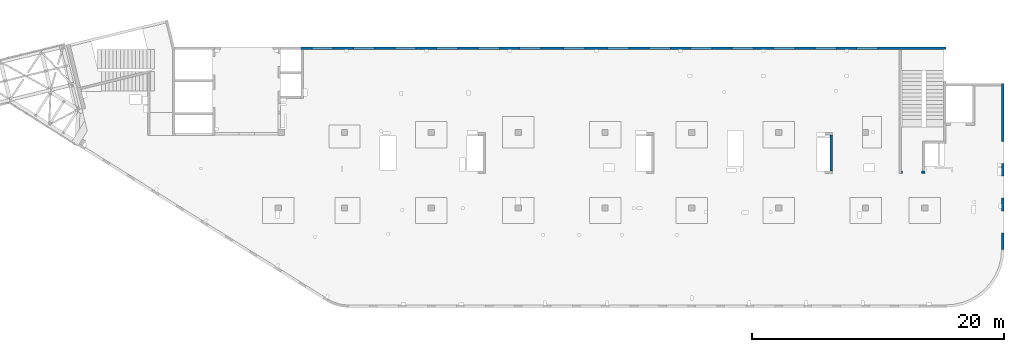
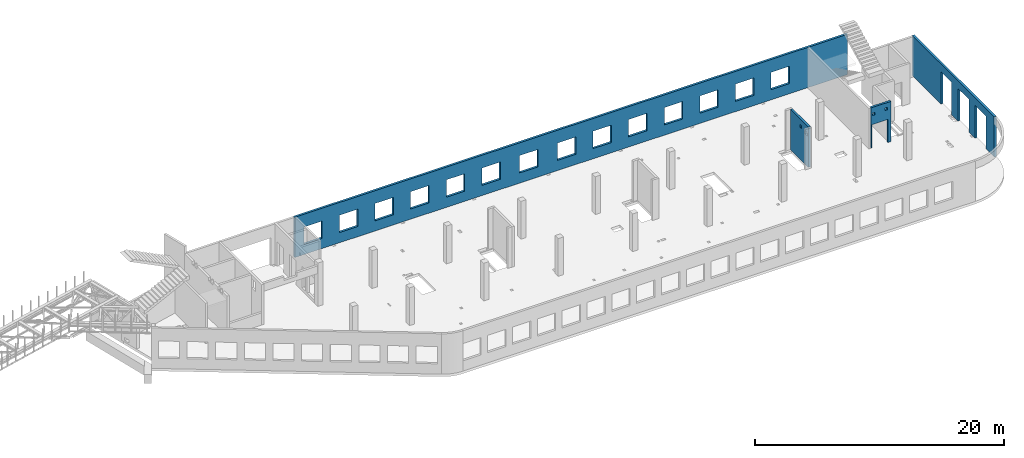
# One storey, part 66 of 66: 4 walls, 22 openings.
"""IFC4 building model written with IfcOpenShell, lengths in millimetres."""

from ifc_helpers import new_model, entity, si_unit, converted_unit, derived_unit, direction, frame, origin, place, context, subcontext, project, spatial, indexed_curve, outline, extrude, polygons, material, type_object, element, save


model = new_model("IFC4")

# Units and contexts
model_context = context("Model", 3, precision=0.01, world=origin(), true_north=direction((6.12303176911189e-17, 1.0)))
plan_context = context("Plan", 3, precision=0.01, world=origin(), true_north=direction((6.12303176911189e-17, 1.0)))
body_context = subcontext(model_context, "Body", "Model", "MODEL_VIEW")
ifc_project = project(units=[si_unit("LENGTHUNIT", "METRE", prefix="MILLI"), si_unit("AREAUNIT", "SQUARE_METRE"), si_unit("VOLUMEUNIT", "CUBIC_METRE"), converted_unit("PLANEANGLEUNIT", "DEGREE", entity("IfcRatioMeasure", 0.0174532925199433), si_unit("PLANEANGLEUNIT", "RADIAN"), dimensions=[0, 0, 0, 0, 0, 0, 0]), si_unit("MASSUNIT", "GRAM", prefix="KILO"), derived_unit("MASSDENSITYUNIT", [(si_unit("MASSUNIT", "GRAM", prefix="KILO"), 1), (si_unit("LENGTHUNIT", "METRE"), -3)]), derived_unit("MOMENTOFINERTIAUNIT", [(si_unit("LENGTHUNIT", "METRE"), 4)]), si_unit("TIMEUNIT", "SECOND"), si_unit("FREQUENCYUNIT", "HERTZ"), si_unit("THERMODYNAMICTEMPERATUREUNIT", "DEGREE_CELSIUS"), derived_unit("THERMALTRANSMITTANCEUNIT", [(si_unit("MASSUNIT", "GRAM", prefix="KILO"), 1), (si_unit("THERMODYNAMICTEMPERATUREUNIT", "KELVIN"), -1), (si_unit("TIMEUNIT", "SECOND"), -3)]), derived_unit("VOLUMETRICFLOWRATEUNIT", [(si_unit("LENGTHUNIT", "METRE"), 3), (si_unit("TIMEUNIT", "SECOND"), -1)]), derived_unit("MASSFLOWRATEUNIT", [(si_unit("MASSUNIT", "GRAM", prefix="KILO"), 1), (si_unit("TIMEUNIT", "SECOND"), -1)]), derived_unit("ROTATIONALFREQUENCYUNIT", [(si_unit("TIMEUNIT", "SECOND"), -1)]), si_unit("ELECTRICCURRENTUNIT", "AMPERE"), si_unit("ELECTRICVOLTAGEUNIT", "VOLT"), si_unit("POWERUNIT", "WATT"), si_unit("FORCEUNIT", "NEWTON", prefix="KILO"), si_unit("ILLUMINANCEUNIT", "LUX"), si_unit("LUMINOUSFLUXUNIT", "LUMEN"), si_unit("LUMINOUSINTENSITYUNIT", "CANDELA"), derived_unit("USERDEFINED", [(si_unit("MASSUNIT", "GRAM", prefix="KILO"), -1), (si_unit("LENGTHUNIT", "METRE"), -2), (si_unit("TIMEUNIT", "SECOND"), 3), (si_unit("LUMINOUSFLUXUNIT", "LUMEN"), 1)]), derived_unit("LINEARVELOCITYUNIT", [(si_unit("LENGTHUNIT", "METRE"), 1), (si_unit("TIMEUNIT", "SECOND"), -1)]), si_unit("PRESSUREUNIT", "PASCAL"), derived_unit("USERDEFINED", [(si_unit("LENGTHUNIT", "METRE"), -2), (si_unit("MASSUNIT", "GRAM", prefix="KILO"), 1), (si_unit("TIMEUNIT", "SECOND"), -2)]), derived_unit("LINEARFORCEUNIT", [(si_unit("MASSUNIT", "GRAM", prefix="KILO"), 1), (si_unit("LENGTHUNIT", "METRE"), 1), (si_unit("TIMEUNIT", "SECOND"), -2), (si_unit("LENGTHUNIT", "METRE"), -1)]), derived_unit("PLANARFORCEUNIT", [(si_unit("MASSUNIT", "GRAM", prefix="KILO"), 1), (si_unit("LENGTHUNIT", "METRE"), 1), (si_unit("TIMEUNIT", "SECOND"), -2), (si_unit("LENGTHUNIT", "METRE"), -2)])], contexts=[model_context, plan_context])

# Site, building, storey
site_placement = place(None, origin())
site = spatial("IfcSite", under=ifc_project, at=site_placement, CompositionType="ELEMENT")
building_placement = place(site_placement, origin())
building = spatial("IfcBuilding", under=site, at=building_placement, CompositionType="ELEMENT")
storey_placement = place(building_placement, frame((0.0, 0.0, 19800.0)))
storey = spatial("IfcBuildingStorey", under=building, at=storey_placement, Name="06", CompositionType="ELEMENT", Elevation=19800.0)

# Wall, openings
ifc_material = material()
wall_type = type_object("IfcWallType", Name=":ADSK_ 25_200", PredefinedType="STANDARD")
wall_1_placement = place(storey_placement, frame((68970.0, 20400.0, -150.0), z_axis=(0.0, 0.0, 1.0), x_axis=(-1.0, 0.0, 0.0)))
wall_1 = element("IfcWall", 1, at=wall_1_placement, inside=storey, type_object=wall_type, material=ifc_material, Name=":ADSK_ 25_200", ObjectType=":ADSK_ 25_200", PredefinedType="NOTDEFINED", context=body_context, shape_type="Tessellation", body=[
    polygons([(48700.0, -100.000000000319, 2700.0), (50400.0, -100.000000000319, 2700.0), (50400.0, -100.000000000319, 1000.00000000001), (48700.0, -100.000000000319, 1000.00000000001), (45400.0, -100.000000000319, 2700.0), (47100.0, -100.000000000319, 2700.0), (47100.0, -100.000000000319, 1000.00000000001), (45400.0, -100.000000000319, 1000.00000000001), (42100.0, -100.000000000315, 2700.0), (43800.0, -100.000000000319, 2700.0), (43800.0, -100.000000000319, 1000.00000000001), (42100.0, -100.000000000315, 1000.00000000001), (38800.0, -100.000000000315, 2700.0), (40500.0, -100.000000000315, 2700.0), (40500.0, -100.000000000315, 1000.00000000001), (38800.0, -100.000000000315, 1000.00000000001), (35500.0, -100.000000000315, 2700.0), (37200.0, -100.000000000315, 2700.0), (37200.0, -100.000000000315, 1000.00000000001), (35500.0, -100.000000000315, 1000.00000000001), (28700.0, -100.000000000315, 2700.0), (30400.0, -100.000000000315, 2700.0), (30400.0, -100.000000000315, 1000.00000000001), (28700.0, -100.000000000315, 1000.00000000001), (25200.0, -100.000000000319, 2700.0), (26900.0, -100.000000000315, 2700.0), (26900.0, -100.000000000315, 1000.00000000001), (25200.0, -100.000000000319, 1000.00000000001), (21900.0, -100.000000000319, 2700.0), (23600.0, -100.000000000319, 2700.0), (23600.0, -100.000000000319, 1000.00000000001), (21900.0, -100.000000000319, 1000.00000000001), (18600.0, -100.000000000319, 2700.0), (20300.0, -100.000000000319, 2700.0), (20300.0, -100.000000000319, 1000.00000000001), (18600.0, -100.000000000319, 1000.00000000001), (15300.0, -100.000000000319, 2700.0), (17000.0, -100.000000000319, 2700.0), (17000.0, -100.000000000319, 1000.00000000001), (15300.0, -100.000000000319, 1000.00000000001), (12000.0, -100.000000000319, 2700.0), (13700.0, -100.000000000319, 2700.0), (13700.0, -100.000000000319, 1000.00000000001), (12000.0, -100.000000000319, 1000.00000000001), (8700.00000000004, -100.000000000319, 2700.0), (10400.0, -100.000000000319, 2700.0), (10400.0, -100.000000000319, 1000.00000000001), (8700.00000000004, -100.000000000319, 1000.00000000001), (5400.00000000004, -100.000000000319, 2700.0), (7100.00000000004, -100.000000000319, 2700.0), (7100.00000000004, -100.000000000319, 1000.00000000001), (5400.00000000004, -100.000000000319, 1000.00000000001), (32200.0, -100.000000000315, 2700.0), (33900.0, -100.000000000315, 2700.0), (33900.0, -100.000000000315, 1000.00000000001), (32200.0, -100.000000000315, 1000.00000000001), (-1.0404017477463e-11, -99.9999999999989, 0.0), (3539.99999999995, -99.9999999999989, 0.0), (51245.0, -99.9999999999989, 0.0), (51245.0, -99.9999999999989, 3950.0), (3539.99999999995, -99.9999999999989, 3950.0), (-1.0404017477463e-11, -99.9999999999989, 3950.0), (-1.03870313266876e-11, 99.9999999999989, 0.0), (-1.03870313266876e-11, 99.9999999999989, 3950.0), (3539.99999999996, 99.9999999999989, 3950.0), (3739.99999999996, 99.9999999999989, 3950.0), (51045.0, 99.9999999999989, 3950.0), (51245.0, 99.9999999999989, 3950.0), (51245.0, 99.9999999999989, 0.0), (51045.0, 99.9999999999989, 0.0), (3739.99999999996, 99.9999999999989, 0.0), (3539.99999999996, 99.9999999999989, 0.0), (50400.0, 99.9999999999989, 2700.0), (48700.0, 99.9999999999989, 2700.0), (48700.0, 99.9999999999989, 1000.00000000001), (50400.0, 99.9999999999989, 1000.00000000001), (47100.0, 99.9999999999989, 2700.0), (45400.0, 99.9999999999989, 2700.0), (45400.0, 99.9999999999989, 1000.00000000001), (47100.0, 99.9999999999989, 1000.00000000001), (43800.0, 99.9999999999989, 2700.0), (42100.0, 100.000000000003, 2700.0), (42100.0, 100.000000000003, 1000.00000000001), (43800.0, 99.9999999999989, 1000.00000000001), (40500.0, 100.000000000003, 2700.0), (38800.0, 100.000000000003, 2700.0), (38800.0, 100.000000000003, 1000.00000000001), (40500.0, 100.000000000003, 1000.00000000001), (37200.0, 100.000000000003, 2700.0), (35500.0, 100.000000000003, 2700.0), (35500.0, 100.000000000003, 1000.00000000001), (37200.0, 100.000000000003, 1000.00000000001), (30400.0, 100.000000000003, 2700.0), (28700.0, 100.000000000003, 2700.0), (28700.0, 100.000000000003, 1000.00000000001), (30400.0, 100.000000000003, 1000.00000000001), (26900.0, 100.000000000003, 2700.0), (25200.0, 99.9999999999989, 2700.0), (25200.0, 99.9999999999989, 1000.00000000001), (26900.0, 100.000000000003, 1000.00000000001), (23600.0, 99.9999999999989, 2700.0), (21900.0, 99.9999999999989, 2700.0), (21900.0, 99.9999999999989, 1000.00000000001), (23600.0, 99.9999999999989, 1000.00000000001), (20300.0, 99.9999999999989, 2700.0), (18600.0, 99.9999999999989, 2700.0), (18600.0, 99.9999999999989, 1000.00000000001), (20300.0, 99.9999999999989, 1000.00000000001), (17000.0, 99.9999999999989, 2700.0), (15300.0, 99.9999999999989, 2700.0), (15300.0, 99.9999999999989, 1000.00000000001), (17000.0, 99.9999999999989, 1000.00000000001), (13700.0, 99.9999999999989, 2700.0), (12000.0, 99.9999999999989, 2700.0), (12000.0, 99.9999999999989, 1000.00000000001), (13700.0, 99.9999999999989, 1000.00000000001), (10400.0, 99.9999999999989, 2700.0), (8700.00000000004, 99.9999999999989, 2700.0), (8700.00000000004, 99.9999999999989, 1000.00000000001), (10400.0, 99.9999999999989, 1000.00000000001), (7100.00000000004, 99.9999999999989, 2700.0), (5400.00000000004, 99.9999999999989, 2700.0), (5400.00000000004, 99.9999999999989, 1000.00000000001), (7100.00000000004, 99.9999999999989, 1000.00000000001), (33900.0, 100.000000000003, 2700.0), (32200.0, 100.000000000003, 2700.0), (32200.0, 100.000000000003, 1000.00000000001), (33900.0, 100.000000000003, 1000.00000000001)], [[[57, 58, 59, 60, 61, 62], [1, 2, 3, 4], [5, 6, 7, 8], [9, 10, 11, 12], [13, 14, 15, 16], [17, 18, 19, 20], [21, 22, 23, 24], [25, 26, 27, 28], [29, 30, 31, 32], [33, 34, 35, 36], [37, 38, 39, 40], [41, 42, 43, 44], [45, 46, 47, 48], [49, 50, 51, 52], [53, 54, 55, 56]], [[63, 64, 65, 66, 67, 68, 69, 70, 71, 72], [73, 74, 75, 76], [77, 78, 79, 80], [81, 82, 83, 84], [85, 86, 87, 88], [89, 90, 91, 92], [93, 94, 95, 96], [97, 98, 99, 100], [101, 102, 103, 104], [105, 106, 107, 108], [109, 110, 111, 112], [113, 114, 115, 116], [117, 118, 119, 120], [121, 122, 123, 124], [125, 126, 127, 128]], [[59, 58, 57, 63, 72, 71, 70, 69]], [[62, 61, 60, 68, 67, 66, 65, 64]], [[57, 62, 64, 63]], [[2, 1, 74, 73]], [[2, 73, 76, 3]], [[3, 76, 75, 4]], [[74, 1, 4, 75]], [[6, 5, 78, 77]], [[6, 77, 80, 7]], [[7, 80, 79, 8]], [[78, 5, 8, 79]], [[10, 9, 82, 81]], [[10, 81, 84, 11]], [[11, 84, 83, 12]], [[82, 9, 12, 83]], [[14, 13, 86, 85]], [[14, 85, 88, 15]], [[15, 88, 87, 16]], [[86, 13, 16, 87]], [[18, 17, 90, 89]], [[18, 89, 92, 19]], [[19, 92, 91, 20]], [[90, 17, 20, 91]], [[22, 21, 94, 93]], [[22, 93, 96, 23]], [[23, 96, 95, 24]], [[94, 21, 24, 95]], [[26, 25, 98, 97]], [[26, 97, 100, 27]], [[27, 100, 99, 28]], [[98, 25, 28, 99]], [[30, 29, 102, 101]], [[30, 101, 104, 31]], [[31, 104, 103, 32]], [[102, 29, 32, 103]], [[34, 33, 106, 105]], [[34, 105, 108, 35]], [[35, 108, 107, 36]], [[106, 33, 36, 107]], [[38, 37, 110, 109]], [[38, 109, 112, 39]], [[39, 112, 111, 40]], [[110, 37, 40, 111]], [[42, 41, 114, 113]], [[42, 113, 116, 43]], [[43, 116, 115, 44]], [[114, 41, 44, 115]], [[46, 45, 118, 117]], [[46, 117, 120, 47]], [[47, 120, 119, 48]], [[118, 45, 48, 119]], [[50, 49, 122, 121]], [[50, 121, 124, 51]], [[51, 124, 123, 52]], [[122, 49, 52, 123]], [[54, 53, 126, 125]], [[54, 125, 128, 55]], [[55, 128, 127, 56]], [[126, 53, 56, 127]], [[60, 59, 69, 68]]], closed=True),
])
placement_1 = place(wall_1_placement, frame((68970.0, 20400.0, 150.0), z_axis=(0.0, 0.0, 1.0), x_axis=(-1.0, 0.0, 0.0)))
element("IfcOpeningElement", 2, at=placement_1, cuts=wall_1, Name=":ADSK_ 25_200", PredefinedType="OPENING", context=body_context, shape_type="SweptSolid", body=[
    extrude(outline(indexed_curve([(-850.000000000002, -849.999999999993), (850.0, -849.999999999993), (850.0, 849.999999999993), (-850.000000000002, 849.999999999993), (-850.000000000002, -849.999999999993)], self_intersect=False)), frame((19420.0, 20500.0, 1700.0), z_axis=(0.0, -1.0, 0.0), x_axis=(-1.0, 0.0, 0.0)), (0.0, 0.0, 1.0), 200.000000000959),
])
element("IfcOpeningElement", 3, at=placement_1, cuts=wall_1, Name=":ADSK_ 25_200", PredefinedType="OPENING", context=body_context, shape_type="SweptSolid", body=[
    extrude(outline(indexed_curve([(-850.000000000002, -849.999999999993), (849.999999999997, -849.999999999993), (849.999999999997, 849.999999999993), (-850.000000000002, 849.999999999993), (-850.000000000002, -849.999999999993)], self_intersect=False)), frame((22720.0, 20500.0, 1700.0), z_axis=(0.0, -1.0, 0.0), x_axis=(-1.0, 0.0, 0.0)), (0.0, 0.0, 1.0), 200.000000000959),
])
element("IfcOpeningElement", 4, at=placement_1, cuts=wall_1, Name=":ADSK_ 25_200", PredefinedType="OPENING", context=body_context, shape_type="SweptSolid", body=[
    extrude(outline(indexed_curve([(-850.000000000002, -849.999999999993), (849.999999999997, -849.999999999993), (849.999999999997, 849.999999999993), (-850.000000000002, 849.999999999993), (-850.000000000002, -849.999999999993)], self_intersect=False)), frame((26020.0, 20500.0, 1700.0), z_axis=(0.0, -1.0, 0.0), x_axis=(-1.0, 0.0, 0.0)), (0.0, 0.0, 1.0), 200.000000000959),
])
element("IfcOpeningElement", 5, at=placement_1, cuts=wall_1, Name=":ADSK_ 25_200", PredefinedType="OPENING", context=body_context, shape_type="SweptSolid", body=[
    extrude(outline(indexed_curve([(-850.000000000002, -849.999999999993), (849.999999999997, -849.999999999993), (849.999999999997, 849.999999999993), (-850.000000000002, 849.999999999993), (-850.000000000002, -849.999999999993)], self_intersect=False)), frame((29320.0, 20500.0, 1700.0), z_axis=(0.0, -1.0, 0.0), x_axis=(-1.0, 0.0, 0.0)), (0.0, 0.0, 1.0), 200.000000000959),
])
element("IfcOpeningElement", 6, at=placement_1, cuts=wall_1, Name=":ADSK_ 25_200", PredefinedType="OPENING", context=body_context, shape_type="SweptSolid", body=[
    extrude(outline(indexed_curve([(-849.999999999997, -849.999999999993), (850.000000000002, -849.999999999993), (850.000000000002, 849.999999999993), (-849.999999999997, 849.999999999993), (-849.999999999997, -849.999999999993)], self_intersect=False)), frame((32620.0, 20500.0, 1700.0), z_axis=(0.0, -1.0, 0.0), x_axis=(-1.0, 0.0, 0.0)), (0.0, 0.0, 1.0), 200.000000000959),
])
element("IfcOpeningElement", 7, at=placement_1, cuts=wall_1, Name=":ADSK_ 25_200", PredefinedType="OPENING", context=body_context, shape_type="SweptSolid", body=[
    extrude(outline(indexed_curve([(-849.999999999997, -849.999999999993), (850.000000000006, -849.999999999993), (850.000000000006, 849.999999999993), (-849.999999999997, 849.999999999993), (-849.999999999997, -849.999999999993)], self_intersect=False)), frame((39420.0, 20500.0, 1700.0), z_axis=(0.0, -1.0, 0.0), x_axis=(-1.0, 0.0, 0.0)), (0.0, 0.0, 1.0), 200.000000000959),
])
element("IfcOpeningElement", 8, at=placement_1, cuts=wall_1, Name=":ADSK_ 25_200", PredefinedType="OPENING", context=body_context, shape_type="SweptSolid", body=[
    extrude(outline(indexed_curve([(-850.000000000006, -849.999999999993), (849.999999999997, -849.999999999993), (849.999999999997, 849.999999999993), (-850.000000000006, 849.999999999993), (-850.000000000006, -849.999999999993)], self_intersect=False)), frame((42920.0, 20500.0, 1700.0), z_axis=(0.0, -1.0, 0.0), x_axis=(-1.0, 0.0, 0.0)), (0.0, 0.0, 1.0), 200.000000000959),
])
element("IfcOpeningElement", 9, at=placement_1, cuts=wall_1, Name=":ADSK_ 25_200", PredefinedType="OPENING", context=body_context, shape_type="SweptSolid", body=[
    extrude(outline(indexed_curve([(-849.999999999997, -849.999999999993), (850.000000000006, -849.999999999993), (850.000000000006, 849.999999999993), (-849.999999999997, 849.999999999993), (-849.999999999997, -849.999999999993)], self_intersect=False)), frame((46220.0, 20500.0, 1700.0), z_axis=(0.0, -1.0, 0.0), x_axis=(-1.0, 0.0, 0.0)), (0.0, 0.0, 1.0), 200.000000000959),
])
element("IfcOpeningElement", 10, at=placement_1, cuts=wall_1, Name=":ADSK_ 25_200", PredefinedType="OPENING", context=body_context, shape_type="SweptSolid", body=[
    extrude(outline(indexed_curve([(-849.999999999997, -849.999999999993), (850.000000000006, -849.999999999993), (850.000000000006, 849.999999999993), (-849.999999999997, 849.999999999993), (-849.999999999997, -849.999999999993)], self_intersect=False)), frame((49520.0, 20500.0, 1700.0), z_axis=(0.0, -1.0, 0.0), x_axis=(-1.0, 0.0, 0.0)), (0.0, 0.0, 1.0), 200.000000000959),
])
element("IfcOpeningElement", 11, at=placement_1, cuts=wall_1, Name=":ADSK_ 25_200", PredefinedType="OPENING", context=body_context, shape_type="SweptSolid", body=[
    extrude(outline(indexed_curve([(-849.999999999997, -849.999999999993), (850.000000000006, -849.999999999993), (850.000000000006, 849.999999999993), (-849.999999999997, 849.999999999993), (-849.999999999997, -849.999999999993)], self_intersect=False)), frame((52820.0, 20500.0, 1700.0), z_axis=(0.0, -1.0, 0.0), x_axis=(-1.0, 0.0, 0.0)), (0.0, 0.0, 1.0), 200.000000000959),
])
element("IfcOpeningElement", 12, at=placement_1, cuts=wall_1, Name=":ADSK_ 25_200", PredefinedType="OPENING", context=body_context, shape_type="SweptSolid", body=[
    extrude(outline(indexed_curve([(-849.999999999997, -849.999999999993), (850.000000000006, -849.999999999993), (850.000000000006, 849.999999999993), (-849.999999999997, 849.999999999993), (-849.999999999997, -849.999999999993)], self_intersect=False)), frame((56120.0, 20500.0, 1700.0), z_axis=(0.0, -1.0, 0.0), x_axis=(-1.0, 0.0, 0.0)), (0.0, 0.0, 1.0), 200.000000000959),
])
element("IfcOpeningElement", 13, at=placement_1, cuts=wall_1, Name=":ADSK_ 25_200", PredefinedType="OPENING", context=body_context, shape_type="SweptSolid", body=[
    extrude(outline(indexed_curve([(-849.999999999997, -849.999999999993), (850.000000000006, -849.999999999993), (850.000000000006, 849.999999999993), (-849.999999999997, 849.999999999993), (-849.999999999997, -849.999999999993)], self_intersect=False)), frame((59420.0, 20500.0, 1700.0), z_axis=(0.0, -1.0, 0.0), x_axis=(-1.0, 0.0, 0.0)), (0.0, 0.0, 1.0), 200.000000000959),
])
element("IfcOpeningElement", 14, at=placement_1, cuts=wall_1, Name=":ADSK_ 25_200", PredefinedType="OPENING", context=body_context, shape_type="SweptSolid", body=[
    extrude(outline(indexed_curve([(-849.999999999997, -849.999999999993), (850.000000000006, -849.999999999993), (850.000000000006, 849.999999999993), (-849.999999999997, 849.999999999993), (-849.999999999997, -849.999999999993)], self_intersect=False)), frame((62720.0, 20500.0, 1700.0), z_axis=(0.0, -1.0, 0.0), x_axis=(-1.0, 0.0, 0.0)), (0.0, 0.0, 1.0), 200.000000000959),
])
element("IfcOpeningElement", 15, at=placement_1, cuts=wall_1, Name=":ADSK_ 25_200", PredefinedType="OPENING", context=body_context, shape_type="SweptSolid", body=[
    extrude(outline(indexed_curve([(-849.999999999997, -849.999999999993), (850.000000000002, -849.999999999993), (850.000000000002, 849.999999999993), (-849.999999999997, 849.999999999993), (-849.999999999997, -849.999999999993)], self_intersect=False)), frame((35920.0, 20500.0, 1700.0), z_axis=(0.0, -1.0, 0.0), x_axis=(-1.0, 0.0, 0.0)), (0.0, 0.0, 1.0), 200.000000000959),
])

wall_2_placement = place(storey_placement, frame((73470.0, 4400.0, -150.0), z_axis=(0.0, 0.0, 1.0), x_axis=(0.0, 1.0, 0.0)))
wall_2 = element("IfcWall", 16, at=wall_2_placement, inside=storey, type_object=wall_type, material=ifc_material, Name=":ADSK_ 25_200", ObjectType=":ADSK_ 25_200", PredefinedType="NOTDEFINED", context=body_context, shape_type="Tessellation", body=[
    polygons([(13170.0, -99.9999999999926, 3950.0), (5.41433564649196e-13, -99.9999999999984, 3950.0), (5.41433564649196e-13, -99.9999999999984, 3200.0), (5.41433564649196e-13, -99.9999999999984, 0.0), (1325.0, -99.9999999999969, 0.0), (1325.0, -99.9999999999969, 3200.0), (3075.0, -99.999999999995, 3200.0), (3075.0, -99.999999999995, 0.0), (4075.0, -100.000000000003, 0.0), (4075.0, -100.000000000003, 3200.0), (5825.0, -100.000000000001, 3200.0), (5825.0, -100.000000000001, 0.0), (6825.0, -99.9999999999995, 0.0), (6825.0, -99.9999999999995, 3200.0), (8575.0, -99.9999999999976, 3200.0), (8575.0, -99.9999999999976, 0.0), (13170.0, -99.9999999999926, 0.0), (0.0, 99.9999999999994, 3950.0), (3410.00000000003, 100.000000000003, 3950.0), (3610.00000000003, 100.000000000003, 3950.0), (5885.00000000002, 99.9999999999973, 3950.0), (6485.00000000003, 99.9999999999979, 3950.0), (6650.00000000004, 99.9999999999981, 3950.0), (6850.00000000003, 99.9999999999983, 3950.0), (12970.0, 99.9999999999964, 3950.0), (13170.0, 99.9999999999966, 3950.0), (13170.0, 99.9999999999966, 0.0), (12970.0, 99.9999999999964, 0.0), (8575.0, 100.0, 0.0), (8575.0, 100.000000000321, 3200.0), (6825.0, 100.000000000319, 3200.0), (6825.0, 99.9999999999983, 0.0), (5825.0, 99.9999999999972, 0.0), (5825.0, 100.000000000318, 3200.0), (4075.0, 100.000000000316, 3200.0), (4075.0, 99.9999999999953, 0.0), (3600.00000000004, 100.000000000003, 0.0), (3300.00000000003, 100.000000000003, 0.0), (3075.0, 100.000000000003, 0.0), (3075.0, 100.000000000315, 3200.0), (1325.0, 100.000000000313, 3200.0), (1325.0, 100.000000000001, 0.0), (0.0, 99.9999999999994, 0.0), (0.0, 99.9999999999994, 3200.0)], [[[1, 2, 3, 4, 5, 6, 7, 8, 9, 10, 11, 12, 13, 14, 15, 16, 17]], [[18, 19, 20, 21, 22, 23, 24, 25, 26, 27, 28, 29, 30, 31, 32, 33, 34, 35, 36, 37, 38, 39, 40, 41, 42, 43, 44]], [[4, 43, 42, 5]], [[2, 1, 26, 25, 24, 23, 22, 21, 20, 19, 18]], [[4, 3, 2, 18, 44, 43]], [[1, 17, 27, 26]], [[14, 31, 30, 15]], [[31, 14, 13, 32]], [[15, 30, 29, 16]], [[10, 35, 34, 11]], [[35, 10, 9, 36]], [[11, 34, 33, 12]], [[6, 41, 40, 7]], [[41, 6, 5, 42]], [[7, 40, 39, 8]], [[36, 9, 8, 39, 38, 37]], [[32, 13, 12, 33]], [[27, 17, 16, 29, 28]]], closed=True),
])
placement_2 = place(wall_2_placement, frame((-4400.0, 73470.0, 150.0), z_axis=(0.0, 0.0, 1.0), x_axis=(0.0, -1.0, 0.0)))
element("IfcOpeningElement", 17, at=placement_2, cuts=wall_2, Name=":ADSK_ 25_200", PredefinedType="OPENING", context=body_context, shape_type="SweptSolid", body=[
    extrude(outline(indexed_curve([(-1600.0, -875.0), (1599.99999999999, -875.0), (1599.99999999999, 875.0), (-1600.0, 875.0), (-1600.0, -875.0)], self_intersect=False)), frame((73570.0, 12100.0, 1450.0), z_axis=(-1.0, 0.0, 0.0), x_axis=(0.0, 0.0, -1.0)), (0.0, 0.0, 1.0), 200.000000000968),
])
element("IfcOpeningElement", 18, at=placement_2, cuts=wall_2, Name=":ADSK_ 25_200", PredefinedType="OPENING", context=body_context, shape_type="SweptSolid", body=[
    extrude(outline(indexed_curve([(-1600.0, -875.0), (1599.99999999999, -875.0), (1599.99999999999, 874.999999999999), (-1600.0, 874.999999999999), (-1600.0, -875.0)], self_intersect=False)), frame((73570.0, 9350.0, 1450.0), z_axis=(-1.0, 0.0, 0.0), x_axis=(0.0, 0.0, -1.0)), (0.0, 0.0, 1.0), 200.000000000968),
])
element("IfcOpeningElement", 19, at=placement_2, cuts=wall_2, Name=":ADSK_ 25_200", PredefinedType="OPENING", context=body_context, shape_type="SweptSolid", body=[
    extrude(outline(indexed_curve([(-1600.0, -874.999999999999), (1599.99999999999, -874.999999999999), (1599.99999999999, 875.0), (-1600.0, 875.0), (-1600.0, -874.999999999999)], self_intersect=False)), frame((73570.0, 6600.0, 1450.0), z_axis=(-1.0, 0.0, 0.0), x_axis=(0.0, 0.0, -1.0)), (0.0, 0.0, 1.0), 200.000000000968),
])

wall_3_placement = place(storey_placement, frame((59830.0, 13500.0, -150.0), z_axis=(0.0, 0.0, 1.0), x_axis=(0.0, -1.0, 0.0)))
wall_3 = element("IfcWall", 20, at=wall_3_placement, inside=storey, type_object=wall_type, material=ifc_material, Name=":ADSK_ 25_200", ObjectType=":ADSK_ 25_200", PredefinedType="NOTDEFINED", context=body_context, shape_type="Tessellation", body=[
    polygons([(0.0, -99.9999999999859, 0.0), (2875.00000000002, -99.9999999999859, 0.0), (2875.00000000002, -99.9999999999859, 3950.0), (0.0, -99.9999999999859, 3950.0), (2360.00000000002, -100.000000000003, 3330.0), (2710.00000000001, -100.000000000003, 3330.0), (2710.00000000001, -100.000000000003, 2980.00000000001), (2360.00000000002, -100.000000000003, 2980.00000000001), (1560.00000000002, -100.000000000003, 3400.0), (1810.00000000002, -100.000000000003, 3400.0), (1810.00000000002, -100.000000000003, 3150.00000000001), (1560.00000000002, -100.000000000003, 3150.00000000001), (2.16573425859679e-12, 100.000000000003, 0.0), (2.16573425859679e-12, 100.000000000003, 3950.0), (2875.00000000002, 100.000000000003, 3950.0), (2875.00000000002, 100.000000000003, 0.0), (2710.00000000002, 100.000000000324, 3330.0), (2360.00000000002, 100.000000000324, 3330.0), (2360.00000000002, 100.000000000324, 2980.00000000001), (2710.00000000002, 100.000000000324, 2980.00000000001), (1810.00000000002, 100.000000000324, 3400.0), (1560.00000000002, 100.000000000324, 3400.0), (1560.00000000002, 100.000000000324, 3150.00000000001), (1810.00000000002, 100.000000000324, 3150.00000000001)], [[[1, 2, 3, 4], [5, 6, 7, 8], [9, 10, 11, 12]], [[13, 14, 15, 16], [17, 18, 19, 20], [21, 22, 23, 24]], [[2, 1, 13, 16]], [[4, 3, 15, 14]], [[1, 4, 14, 13]], [[3, 2, 16, 15]], [[18, 17, 6, 5]], [[18, 5, 8, 19]], [[19, 8, 7, 20]], [[6, 17, 20, 7]], [[22, 21, 10, 9]], [[22, 9, 12, 23]], [[23, 12, 11, 24]], [[10, 21, 24, 11]]], closed=True),
])
placement_3 = place(wall_3_placement, frame((13500.0, -59830.0, 150.0), z_axis=(0.0, 0.0, 1.0), x_axis=(0.0, 1.0, 0.0)))
element("IfcOpeningElement", 21, at=placement_3, cuts=wall_3, Name=":ADSK_ 25_200", PredefinedType="OPENING", context=body_context, shape_type="SweptSolid", body=[
    extrude(outline(indexed_curve([(-174.999999999995, -174.999999999999), (174.999999999991, -174.999999999999), (174.999999999991, 175.000000000001), (-174.999999999995, 175.000000000001), (-174.999999999995, -174.999999999999)], self_intersect=False)), frame((59730.0, 10965.0, 3005.0), z_axis=(1.0, 0.0, 0.0), x_axis=(0.0, 0.0, -1.0)), (0.0, 0.0, 1.0), 200.000000000968),
])
element("IfcOpeningElement", 22, at=placement_3, cuts=wall_3, Name=":ADSK_ 25_200", PredefinedType="OPENING", context=body_context, shape_type="SweptSolid", body=[
    extrude(outline(indexed_curve([(-124.999999999993, -125.0), (124.999999999993, -125.0), (124.999999999993, 125.0), (-124.999999999993, 125.0), (-124.999999999993, -125.0)], self_intersect=False)), frame((59730.0, 11815.0, 3125.0), z_axis=(1.0, 0.0, 0.0), x_axis=(0.0, 0.0, -1.0)), (0.0, 0.0, 1.0), 200.000000000968),
])

wall_4_placement = place(storey_placement, frame((65430.0, 10525.0, -150.0)))
wall_4 = element("IfcWall", 23, at=wall_4_placement, inside=storey, type_object=wall_type, material=ifc_material, Name=":ADSK_ 25_200", ObjectType=":ADSK_ 25_200", PredefinedType="NOTDEFINED", context=body_context, shape_type="Tessellation", body=[
    polygons([(1850.0, -100.000000000001, 3950.0), (0.0, -100.000000000001, 3950.0), (0.0, -100.000000000001, 0.0), (75.0000000000003, -100.000000000001, 0.0), (75.0000000000003, -100.000000000001, 2279.99999999804), (1575.00000000001, -100.000000000001, 2279.99999999804), (1575.00000000001, -100.000000000001, 0.0), (1850.0, -100.000000000001, 0.0), (125.000000000006, -100.000000000001, 3400.0), (374.999999999993, -100.000000000001, 3400.0), (374.999999999993, -100.000000000001, 3150.00000000001), (125.000000000006, -100.000000000001, 3150.00000000001), (1274.99999999999, -100.000000000001, 3490.0), (1524.99999999998, -100.000000000001, 3490.0), (1524.99999999998, -100.000000000001, 3240.00000000001), (1274.99999999999, -100.000000000001, 3240.00000000001), (0.0, 99.9999999999989, 3950.0), (1650.0, 99.9999999999989, 3950.0), (1850.0, 99.9999999999989, 3950.0), (1850.0, 99.9999999999989, 0.0), (1650.0, 99.9999999999989, 0.0), (1575.00000000001, 99.9999999999989, 0.0), (1575.00000000001, 99.9999999999989, 2279.99999999804), (75.0000000000003, 99.9999999999989, 2279.99999999804), (75.0000000000003, 99.9999999999989, 0.0), (0.0, 99.9999999999989, 0.0), (374.999999999993, 100.000000000322, 3400.0), (125.000000000006, 100.000000000322, 3400.0), (125.000000000006, 100.000000000322, 3150.00000000001), (374.999999999993, 100.000000000322, 3150.00000000001), (1524.99999999998, 100.000000000322, 3490.0), (1274.99999999999, 100.000000000322, 3490.0), (1274.99999999999, 100.000000000322, 3240.00000000001), (1524.99999999998, 100.000000000322, 3240.00000000001), (1850.0, 39.9999999999454, 3950.0)], [[[1, 2, 3, 4, 5, 6, 7, 8], [9, 10, 11, 12], [13, 14, 15, 16]], [[17, 18, 19, 20, 21, 22, 23, 24, 25, 26], [27, 28, 29, 30], [31, 32, 33, 34]], [[3, 26, 25, 4]], [[2, 1, 35, 19, 18, 17]], [[3, 2, 17, 26]], [[1, 8, 20, 19, 35]], [[23, 6, 5, 24]], [[24, 5, 4, 25]], [[6, 23, 22, 7]], [[9, 28, 27, 10]], [[28, 9, 12, 29]], [[29, 12, 11, 30]], [[10, 27, 30, 11]], [[32, 31, 14, 13]], [[32, 13, 16, 33]], [[33, 16, 15, 34]], [[14, 31, 34, 15]], [[20, 8, 7, 22, 21]]], closed=True),
])
placement_4 = place(wall_4_placement, frame((-65430.0, -10525.0, 150.0)))
element("IfcOpeningElement", 24, at=placement_4, cuts=wall_4, Name=":ADSK_ 25_200", PredefinedType="OPENING", context=body_context, shape_type="SweptSolid", body=[
    extrude(outline(indexed_curve([(-1139.99999999902, -750.000000000003), (1139.99999999902, -750.000000000003), (1139.99999999902, 749.999999999994), (-1139.99999999902, 749.999999999994), (-1139.99999999902, -750.000000000003)], self_intersect=False)), frame((66255.0, 10325.0, 990.0), z_axis=(0.0, 1.0, 0.0), x_axis=(0.0, 0.0, -1.0)), (0.0, 0.0, 1.0), 400.000000001943),
])
element("IfcOpeningElement", 25, at=placement_4, cuts=wall_4, Name=":ADSK_ 25_200", PredefinedType="OPENING", context=body_context, shape_type="SweptSolid", body=[
    extrude(outline(indexed_curve([(-124.999999999993, -124.999999999998), (124.999999999993, -124.999999999998), (124.999999999993, 125.000000000006), (-124.999999999993, 125.000000000006), (-124.999999999993, -124.999999999998)], self_intersect=False)), frame((65680.0, 10425.0, 3125.0), z_axis=(0.0, 1.0, 0.0), x_axis=(0.0, 0.0, -1.0)), (0.0, 0.0, 1.0), 200.000000000962),
])
element("IfcOpeningElement", 26, at=placement_4, cuts=wall_4, Name=":ADSK_ 25_200", PredefinedType="OPENING", context=body_context, shape_type="SweptSolid", body=[
    extrude(outline(indexed_curve([(-124.999999999993, -124.999999999998), (124.999999999993, -124.999999999998), (124.999999999993, 125.000000000006), (-124.999999999993, 125.000000000006), (-124.999999999993, -124.999999999998)], self_intersect=False)), frame((66830.0, 10425.0, 3215.0), z_axis=(0.0, 1.0, 0.0), x_axis=(0.0, 0.0, -1.0)), (0.0, 0.0, 1.0), 200.000000000962),
])

save(model, "model.ifc")
